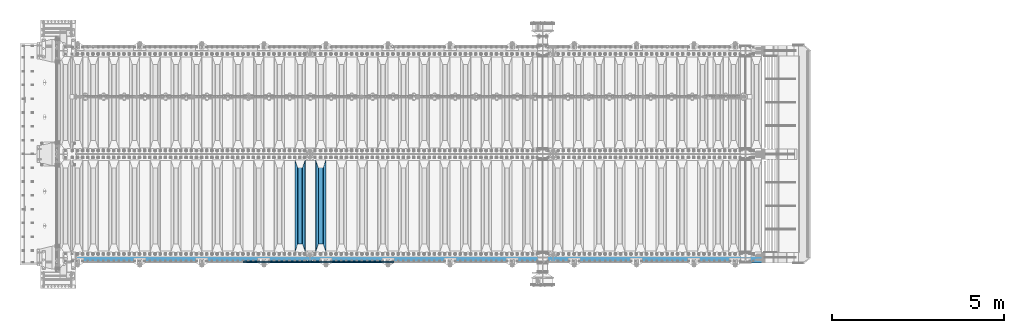
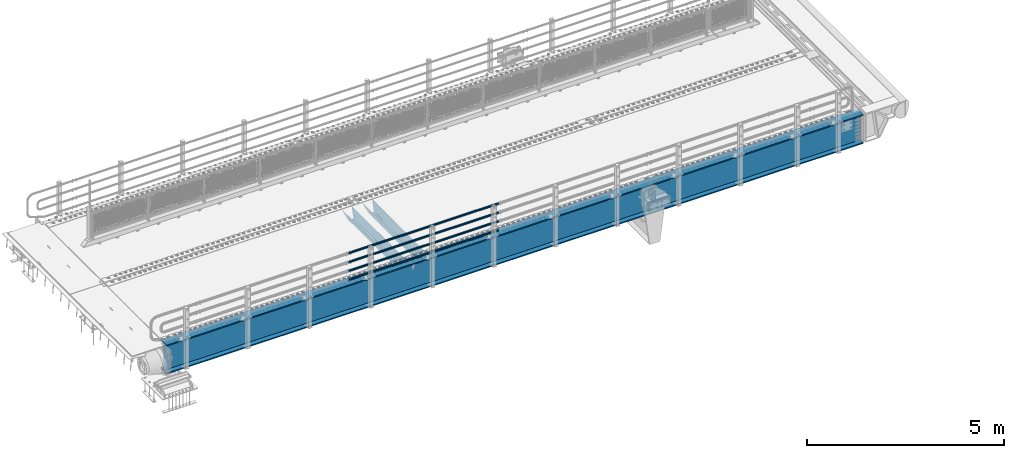
# One storey, part 118 of 242: 7 beams.
"""IFC2X3 building model written with IfcOpenShell, lengths in millimetres."""

from ifc_helpers import new_model, si_unit, frame, origin_with_axes, place, context, subcontext, project, spatial, faceted_brep, material, type_object, element, save


model = new_model("IFC2X3")

# Units and contexts
model_context = context("Model", 3, precision=1e-05, world=origin_with_axes())
body_context = subcontext(model_context, "Body", "Model", "MODEL_VIEW")
ifc_project = project(units=[si_unit("LENGTHUNIT", "METRE", prefix="MILLI"), si_unit("AREAUNIT", "SQUARE_METRE"), si_unit("VOLUMEUNIT", "CUBIC_METRE"), si_unit("MASSUNIT", "GRAM", prefix="KILO"), si_unit("TIMEUNIT", "SECOND"), si_unit("PLANEANGLEUNIT", "RADIAN"), si_unit("SOLIDANGLEUNIT", "STERADIAN"), si_unit("THERMODYNAMICTEMPERATUREUNIT", "DEGREE_CELSIUS"), si_unit("LUMINOUSINTENSITYUNIT", "LUMEN")], contexts=[model_context])

# Site, building, storey
site_placement = place(None, origin_with_axes())
site = spatial("IfcSite", under=ifc_project, at=site_placement, CompositionType="ELEMENT")
building_placement = place(site_placement, origin_with_axes())
building = spatial("IfcBuilding", under=site, at=building_placement, Name="Standard", CompositionType="ELEMENT")
storey_placement = place(building_placement, origin_with_axes())
storey = spatial("IfcBuildingStorey", under=building, at=storey_placement, Name="Undefined", CompositionType="ELEMENT", Elevation=0.0)

# Beams
ifc_material_1 = material()
beam_type_1 = type_object("IfcBeamType", PredefinedType="NOTDEFINED")
beam_1_placement = place(storey_placement, frame((-32722.0000000001, -24129.8499999999, 149.849999999726), z_axis=(0.0, 0.0, -1.0), x_axis=(-1.0, 0.0, 0.0)))
element("IfcBeam", 1, at=beam_1_placement, inside=storey, type_object=beam_type_1, material=ifc_material_1, context=body_context, shape_type="Brep", body=[
    faceted_brep([(0.0, -26.5499999999993, 0.0), (0.0, -24.5290015881765, 10.1602451292931), (4384.00249699992, -24.5290015881765, 10.1602451292931), (4384.00249699992, -26.5499999999993, 0.0), (0.0, -18.7736850405017, 18.7736850405028), (4384.00249699992, -18.7736850405017, 18.7736850405028), (0.0, -10.1602451292929, 24.5290015881747), (4384.00249699992, -10.1602451292929, 24.5290015881747), (0.0, 0.0, 26.55), (4384.00249699992, 0.0, 26.55), (0.0, 10.1602451292929, 24.5290015881747), (4384.00249699992, 10.1602451292929, 24.5290015881747), (0.0, 18.7736850405017, 18.7736850405028), (4384.00249699992, 18.7736850405017, 18.7736850405028), (0.0, 24.5290015881765, 10.1602451292931), (4384.00249699992, 24.5290015881765, 10.1602451292931), (0.0, 26.5499999999993, 0.0), (4384.00249699992, 26.5499999999993, 0.0), (0.0, 24.5290015881765, -10.1602451292931), (4384.00249699992, 24.5290015881765, -10.1602451292931), (0.0, 18.7736850405017, -18.7736850405028), (4384.00249699992, 18.7736850405017, -18.7736850405028), (0.0, 10.1602451292929, -24.5290015881747), (4384.00249699992, 10.1602451292929, -24.5290015881747), (0.0, 0.0, -26.55), (4384.00249699992, 0.0, -26.55), (0.0, -10.1602451292929, -24.5290015881747), (4384.00249699992, -10.1602451292929, -24.5290015881747), (0.0, -18.7736850405017, -18.7736850405028), (4384.00249699992, -18.7736850405017, -18.7736850405028), (0.0, -24.5290015881765, -10.1602451292931), (4384.00249699992, -24.5290015881765, -10.1602451292931), (0.0, -30.1500000000015, 0.0), (0.0, -27.8549679052157, -11.5379054858058), (4384.00249699992, -27.8549679052157, -11.5379054858075), (4384.00249699992, -30.1500000000015, 0.0), (0.0, -21.3192694527752, -21.3192694527752), (4384.00249699992, -21.3192694527752, -21.3192694527744), (0.0, -11.5379054858058, -27.8549679052157), (4384.00249699992, -11.5379054858058, -27.8549679052153), (0.0, 0.0, -30.1500000000015), (4384.00249699992, 0.0, -30.15), (0.0, 11.5379054858058, -27.8549679052157), (4384.00249699992, 11.5379054858058, -27.8549679052153), (0.0, 21.3192694527752, -21.3192694527752), (4384.00249699992, 21.3192694527752, -21.3192694527744), (0.0, 27.8549679052157, -11.5379054858058), (4384.00249699992, 27.8549679052157, -11.5379054858074), (0.0, 30.1500000000015, 0.0), (4384.00249699992, 30.1500000000015, 0.0), (0.0, 27.8549679052157, 11.5379054858058), (4384.00249699992, 27.8549679052157, 11.5379054858075), (0.0, 21.3192694527752, 21.3192694527752), (4384.00249699992, 21.3192694527752, 21.3192694527744), (0.0, 11.5379054858058, 27.8549679052157), (4384.00249699992, 11.5379054858058, 27.8549679052153), (0.0, 0.0, 30.1500000000015), (4384.00249699992, 0.0, 30.15), (0.0, -11.5379054858058, 27.8549679052157), (4384.00249699992, -11.5379054858058, 27.8549679052153), (0.0, -21.3192694527752, 21.3192694527752), (4384.00249699992, -21.3192694527752, 21.3192694527744), (0.0, -27.8549679052157, 11.5379054858058), (4384.00249699992, -27.8549679052157, 11.5379054858075)], [[[0, 1, 2, 3]], [[1, 4, 5, 2]], [[4, 6, 7, 5]], [[6, 8, 9, 7]], [[8, 10, 11, 9]], [[10, 12, 13, 11]], [[12, 14, 15, 13]], [[14, 16, 17, 15]], [[16, 18, 19, 17]], [[18, 20, 21, 19]], [[20, 22, 23, 21]], [[22, 24, 25, 23]], [[24, 26, 27, 25]], [[26, 28, 29, 27]], [[28, 30, 31, 29]], [[30, 0, 3, 31]], [[32, 33, 34, 35]], [[33, 36, 37, 34]], [[36, 38, 39, 37]], [[38, 40, 41, 39]], [[40, 42, 43, 41]], [[42, 44, 45, 43]], [[44, 46, 47, 45]], [[46, 48, 49, 47]], [[48, 50, 51, 49]], [[50, 52, 53, 51]], [[52, 54, 55, 53]], [[54, 56, 57, 55]], [[56, 58, 59, 57]], [[58, 60, 61, 59]], [[60, 62, 63, 61]], [[62, 32, 35, 63]], [[37, 39, 41, 43, 45, 47, 49, 51, 53, 55, 57, 59, 61, 63, 35, 34], [5, 7, 9, 11, 13, 15, 17, 19, 21, 23, 25, 27, 29, 31, 3, 2]], [[62, 60, 58, 56, 54, 52, 50, 48, 46, 44, 42, 40, 38, 36, 33, 32], [30, 28, 26, 24, 22, 20, 18, 16, 14, 12, 10, 8, 6, 4, 1, 0]]]),
])
beam_2_placement = place(storey_placement, frame((-32722.0000000001, -24129.8499999999, 420.149999999729), z_axis=(0.0, 0.0, -1.0), x_axis=(-1.0, 0.0, 0.0)))
element("IfcBeam", 2, at=beam_2_placement, inside=storey, type_object=beam_type_1, material=ifc_material_1, context=body_context, shape_type="Brep", body=[
    faceted_brep([(0.0, -26.5499999999993, 0.0), (0.0, -24.5290015881765, 10.1602451292931), (4384.00249699992, -24.5290015881765, 10.1602451292931), (4384.00249699992, -26.5499999999993, 0.0), (0.0, -18.7736850405017, 18.7736850405028), (4384.00249699992, -18.7736850405017, 18.7736850405028), (0.0, -10.1602451292929, 24.5290015881747), (4384.00249699992, -10.1602451292929, 24.5290015881747), (0.0, 0.0, 26.55), (4384.00249699992, 0.0, 26.55), (0.0, 10.1602451292929, 24.5290015881747), (4384.00249699992, 10.1602451292929, 24.5290015881747), (0.0, 18.7736850405017, 18.7736850405028), (4384.00249699992, 18.7736850405017, 18.7736850405028), (0.0, 24.5290015881765, 10.1602451292931), (4384.00249699992, 24.5290015881765, 10.1602451292931), (0.0, 26.5499999999993, 0.0), (4384.00249699992, 26.5499999999993, 0.0), (0.0, 24.5290015881765, -10.1602451292931), (4384.00249699992, 24.5290015881765, -10.1602451292931), (0.0, 18.7736850405017, -18.7736850405028), (4384.00249699992, 18.7736850405017, -18.7736850405028), (0.0, 10.1602451292929, -24.5290015881747), (4384.00249699992, 10.1602451292929, -24.5290015881747), (0.0, 0.0, -26.55), (4384.00249699992, 0.0, -26.55), (0.0, -10.1602451292929, -24.5290015881747), (4384.00249699992, -10.1602451292929, -24.5290015881747), (0.0, -18.7736850405017, -18.7736850405028), (4384.00249699992, -18.7736850405017, -18.7736850405028), (0.0, -24.5290015881765, -10.1602451292931), (4384.00249699992, -24.5290015881765, -10.1602451292931), (0.0, -30.1500000000015, 0.0), (0.0, -27.8549679052157, -11.5379054858058), (4384.00249699992, -27.8549679052157, -11.5379054858075), (4384.00249699992, -30.1500000000015, 0.0), (0.0, -21.3192694527752, -21.3192694527752), (4384.00249699992, -21.3192694527752, -21.3192694527744), (0.0, -11.5379054858058, -27.8549679052157), (4384.00249699992, -11.5379054858058, -27.8549679052153), (0.0, 0.0, -30.1500000000015), (4384.00249699992, 0.0, -30.15), (0.0, 11.5379054858058, -27.8549679052157), (4384.00249699992, 11.5379054858058, -27.8549679052153), (0.0, 21.3192694527752, -21.3192694527752), (4384.00249699992, 21.3192694527752, -21.3192694527744), (0.0, 27.8549679052157, -11.5379054858058), (4384.00249699992, 27.8549679052157, -11.5379054858074), (0.0, 30.1500000000015, 0.0), (4384.00249699992, 30.1500000000015, 0.0), (0.0, 27.8549679052157, 11.5379054858058), (4384.00249699992, 27.8549679052157, 11.5379054858075), (0.0, 21.3192694527752, 21.3192694527752), (4384.00249699992, 21.3192694527752, 21.3192694527744), (0.0, 11.5379054858058, 27.8549679052157), (4384.00249699992, 11.5379054858058, 27.8549679052153), (0.0, 0.0, 30.1500000000015), (4384.00249699992, 0.0, 30.15), (0.0, -11.5379054858058, 27.8549679052157), (4384.00249699992, -11.5379054858058, 27.8549679052153), (0.0, -21.3192694527752, 21.3192694527752), (4384.00249699992, -21.3192694527752, 21.3192694527744), (0.0, -27.8549679052157, 11.5379054858058), (4384.00249699992, -27.8549679052157, 11.5379054858075)], [[[0, 1, 2, 3]], [[1, 4, 5, 2]], [[4, 6, 7, 5]], [[6, 8, 9, 7]], [[8, 10, 11, 9]], [[10, 12, 13, 11]], [[12, 14, 15, 13]], [[14, 16, 17, 15]], [[16, 18, 19, 17]], [[18, 20, 21, 19]], [[20, 22, 23, 21]], [[22, 24, 25, 23]], [[24, 26, 27, 25]], [[26, 28, 29, 27]], [[28, 30, 31, 29]], [[30, 0, 3, 31]], [[32, 33, 34, 35]], [[33, 36, 37, 34]], [[36, 38, 39, 37]], [[38, 40, 41, 39]], [[40, 42, 43, 41]], [[42, 44, 45, 43]], [[44, 46, 47, 45]], [[46, 48, 49, 47]], [[48, 50, 51, 49]], [[50, 52, 53, 51]], [[52, 54, 55, 53]], [[54, 56, 57, 55]], [[56, 58, 59, 57]], [[58, 60, 61, 59]], [[60, 62, 63, 61]], [[62, 32, 35, 63]], [[37, 39, 41, 43, 45, 47, 49, 51, 53, 55, 57, 59, 61, 63, 35, 34], [5, 7, 9, 11, 13, 15, 17, 19, 21, 23, 25, 27, 29, 31, 3, 2]], [[62, 60, 58, 56, 54, 52, 50, 48, 46, 44, 42, 40, 38, 36, 33, 32], [30, 28, 26, 24, 22, 20, 18, 16, 14, 12, 10, 8, 6, 4, 1, 0]]]),
])
beam_3_placement = place(storey_placement, frame((-32722.0000000001, -24129.8499999999, 969.849999999726), z_axis=(0.0, 0.0, -1.0), x_axis=(-1.0, 0.0, 0.0)))
element("IfcBeam", 3, at=beam_3_placement, inside=storey, type_object=beam_type_1, material=ifc_material_1, context=body_context, shape_type="Brep", body=[
    faceted_brep([(0.0, -26.5499999999993, 0.0), (0.0, -24.5290015881765, 10.1602451292931), (4384.00249699992, -24.5290015881765, 10.1602451292931), (4384.00249699992, -26.5499999999993, 0.0), (0.0, -18.7736850405017, 18.7736850405028), (4384.00249699992, -18.7736850405017, 18.7736850405028), (0.0, -10.1602451292929, 24.5290015881747), (4384.00249699992, -10.1602451292929, 24.5290015881747), (0.0, 0.0, 26.55), (4384.00249699992, 0.0, 26.55), (0.0, 10.1602451292929, 24.5290015881747), (4384.00249699992, 10.1602451292929, 24.5290015881747), (0.0, 18.7736850405017, 18.7736850405028), (4384.00249699992, 18.7736850405017, 18.7736850405028), (0.0, 24.5290015881765, 10.1602451292931), (4384.00249699992, 24.5290015881765, 10.1602451292931), (0.0, 26.5499999999993, 0.0), (4384.00249699992, 26.5499999999993, 0.0), (0.0, 24.5290015881765, -10.1602451292931), (4384.00249699992, 24.5290015881765, -10.1602451292931), (0.0, 18.7736850405017, -18.7736850405028), (4384.00249699992, 18.7736850405017, -18.7736850405028), (0.0, 10.1602451292929, -24.5290015881747), (4384.00249699992, 10.1602451292929, -24.5290015881747), (0.0, 0.0, -26.55), (4384.00249699992, 0.0, -26.55), (0.0, -10.1602451292929, -24.5290015881747), (4384.00249699992, -10.1602451292929, -24.5290015881747), (0.0, -18.7736850405017, -18.7736850405028), (4384.00249699992, -18.7736850405017, -18.7736850405028), (0.0, -24.5290015881765, -10.1602451292931), (4384.00249699992, -24.5290015881765, -10.1602451292931), (0.0, -30.1500000000015, 0.0), (0.0, -27.8549679052157, -11.5379054858058), (4384.00249699992, -27.8549679052157, -11.5379054858075), (4384.00249699992, -30.1500000000015, 0.0), (0.0, -21.3192694527752, -21.3192694527752), (4384.00249699992, -21.3192694527752, -21.3192694527744), (0.0, -11.5379054858058, -27.8549679052157), (4384.00249699992, -11.5379054858058, -27.8549679052153), (0.0, 0.0, -30.1500000000015), (4384.00249699992, 0.0, -30.15), (0.0, 11.5379054858058, -27.8549679052157), (4384.00249699992, 11.5379054858058, -27.8549679052153), (0.0, 21.3192694527752, -21.3192694527752), (4384.00249699992, 21.3192694527752, -21.3192694527744), (0.0, 27.8549679052157, -11.5379054858058), (4384.00249699992, 27.8549679052157, -11.5379054858074), (0.0, 30.1500000000015, 0.0), (4384.00249699992, 30.1500000000015, 0.0), (0.0, 27.8549679052157, 11.5379054858058), (4384.00249699992, 27.8549679052157, 11.5379054858075), (0.0, 21.3192694527752, 21.3192694527752), (4384.00249699992, 21.3192694527752, 21.3192694527744), (0.0, 11.5379054858058, 27.8549679052157), (4384.00249699992, 11.5379054858058, 27.8549679052153), (0.0, 0.0, 30.1500000000015), (4384.00249699992, 0.0, 30.15), (0.0, -11.5379054858058, 27.8549679052157), (4384.00249699992, -11.5379054858058, 27.8549679052153), (0.0, -21.3192694527752, 21.3192694527752), (4384.00249699992, -21.3192694527752, 21.3192694527744), (0.0, -27.8549679052157, 11.5379054858058), (4384.00249699992, -27.8549679052157, 11.5379054858075)], [[[0, 1, 2, 3]], [[1, 4, 5, 2]], [[4, 6, 7, 5]], [[6, 8, 9, 7]], [[8, 10, 11, 9]], [[10, 12, 13, 11]], [[12, 14, 15, 13]], [[14, 16, 17, 15]], [[16, 18, 19, 17]], [[18, 20, 21, 19]], [[20, 22, 23, 21]], [[22, 24, 25, 23]], [[24, 26, 27, 25]], [[26, 28, 29, 27]], [[28, 30, 31, 29]], [[30, 0, 3, 31]], [[32, 33, 34, 35]], [[33, 36, 37, 34]], [[36, 38, 39, 37]], [[38, 40, 41, 39]], [[40, 42, 43, 41]], [[42, 44, 45, 43]], [[44, 46, 47, 45]], [[46, 48, 49, 47]], [[48, 50, 51, 49]], [[50, 52, 53, 51]], [[52, 54, 55, 53]], [[54, 56, 57, 55]], [[56, 58, 59, 57]], [[58, 60, 61, 59]], [[60, 62, 63, 61]], [[62, 32, 35, 63]], [[37, 39, 41, 43, 45, 47, 49, 51, 53, 55, 57, 59, 61, 63, 35, 34], [5, 7, 9, 11, 13, 15, 17, 19, 21, 23, 25, 27, 29, 31, 3, 2]], [[62, 60, 58, 56, 54, 52, 50, 48, 46, 44, 42, 40, 38, 36, 33, 32], [30, 28, 26, 24, 22, 20, 18, 16, 14, 12, 10, 8, 6, 4, 1, 0]]]),
])
beam_4_placement = place(storey_placement, frame((-32722.0000000001, -24129.8499999999, 689.849999999726), z_axis=(0.0, 0.0, -1.0), x_axis=(-1.0, 0.0, 0.0)))
element("IfcBeam", 4, at=beam_4_placement, inside=storey, type_object=beam_type_1, material=ifc_material_1, context=body_context, shape_type="Brep", body=[
    faceted_brep([(0.0, -26.5499999999993, 0.0), (0.0, -24.5290015881765, 10.1602451292931), (4384.00249699992, -24.5290015881765, 10.1602451292931), (4384.00249699992, -26.5499999999993, 0.0), (0.0, -18.7736850405017, 18.7736850405028), (4384.00249699992, -18.7736850405017, 18.7736850405028), (0.0, -10.1602451292929, 24.5290015881747), (4384.00249699992, -10.1602451292929, 24.5290015881747), (0.0, 0.0, 26.55), (4384.00249699992, 0.0, 26.55), (0.0, 10.1602451292929, 24.5290015881747), (4384.00249699992, 10.1602451292929, 24.5290015881747), (0.0, 18.7736850405017, 18.7736850405028), (4384.00249699992, 18.7736850405017, 18.7736850405028), (0.0, 24.5290015881765, 10.1602451292931), (4384.00249699992, 24.5290015881765, 10.1602451292931), (0.0, 26.5499999999993, 0.0), (4384.00249699992, 26.5499999999993, 0.0), (0.0, 24.5290015881765, -10.1602451292931), (4384.00249699992, 24.5290015881765, -10.1602451292931), (0.0, 18.7736850405017, -18.7736850405028), (4384.00249699992, 18.7736850405017, -18.7736850405028), (0.0, 10.1602451292929, -24.5290015881747), (4384.00249699992, 10.1602451292929, -24.5290015881747), (0.0, 0.0, -26.55), (4384.00249699992, 0.0, -26.55), (0.0, -10.1602451292929, -24.5290015881747), (4384.00249699992, -10.1602451292929, -24.5290015881747), (0.0, -18.7736850405017, -18.7736850405028), (4384.00249699992, -18.7736850405017, -18.7736850405028), (0.0, -24.5290015881765, -10.1602451292931), (4384.00249699992, -24.5290015881765, -10.1602451292931), (0.0, -30.1500000000015, 0.0), (0.0, -27.8549679052157, -11.5379054858058), (4384.00249699992, -27.8549679052157, -11.5379054858075), (4384.00249699992, -30.1500000000015, 0.0), (0.0, -21.3192694527752, -21.3192694527752), (4384.00249699992, -21.3192694527752, -21.3192694527744), (0.0, -11.5379054858058, -27.8549679052157), (4384.00249699992, -11.5379054858058, -27.8549679052153), (0.0, 0.0, -30.1500000000015), (4384.00249699992, 0.0, -30.15), (0.0, 11.5379054858058, -27.8549679052157), (4384.00249699992, 11.5379054858058, -27.8549679052153), (0.0, 21.3192694527752, -21.3192694527752), (4384.00249699992, 21.3192694527752, -21.3192694527744), (0.0, 27.8549679052157, -11.5379054858058), (4384.00249699992, 27.8549679052157, -11.5379054858074), (0.0, 30.1500000000015, 0.0), (4384.00249699992, 30.1500000000015, 0.0), (0.0, 27.8549679052157, 11.5379054858058), (4384.00249699992, 27.8549679052157, 11.5379054858075), (0.0, 21.3192694527752, 21.3192694527752), (4384.00249699992, 21.3192694527752, 21.3192694527744), (0.0, 11.5379054858058, 27.8549679052157), (4384.00249699992, 11.5379054858058, 27.8549679052153), (0.0, 0.0, 30.1500000000015), (4384.00249699992, 0.0, 30.15), (0.0, -11.5379054858058, 27.8549679052157), (4384.00249699992, -11.5379054858058, 27.8549679052153), (0.0, -21.3192694527752, 21.3192694527752), (4384.00249699992, -21.3192694527752, 21.3192694527744), (0.0, -27.8549679052157, 11.5379054858058), (4384.00249699992, -27.8549679052157, 11.5379054858075)], [[[0, 1, 2, 3]], [[1, 4, 5, 2]], [[4, 6, 7, 5]], [[6, 8, 9, 7]], [[8, 10, 11, 9]], [[10, 12, 13, 11]], [[12, 14, 15, 13]], [[14, 16, 17, 15]], [[16, 18, 19, 17]], [[18, 20, 21, 19]], [[20, 22, 23, 21]], [[22, 24, 25, 23]], [[24, 26, 27, 25]], [[26, 28, 29, 27]], [[28, 30, 31, 29]], [[30, 0, 3, 31]], [[32, 33, 34, 35]], [[33, 36, 37, 34]], [[36, 38, 39, 37]], [[38, 40, 41, 39]], [[40, 42, 43, 41]], [[42, 44, 45, 43]], [[44, 46, 47, 45]], [[46, 48, 49, 47]], [[48, 50, 51, 49]], [[50, 52, 53, 51]], [[52, 54, 55, 53]], [[54, 56, 57, 55]], [[56, 58, 59, 57]], [[58, 60, 61, 59]], [[60, 62, 63, 61]], [[62, 32, 35, 63]], [[37, 39, 41, 43, 45, 47, 49, 51, 53, 55, 57, 59, 61, 63, 35, 34], [5, 7, 9, 11, 13, 15, 17, 19, 21, 23, 25, 27, 29, 31, 3, 2]], [[62, 60, 58, 56, 54, 52, 50, 48, 46, 44, 42, 40, 38, 36, 33, 32], [30, 28, 26, 24, 22, 20, 18, 16, 14, 12, 10, 8, 6, 4, 1, 0]]]),
])
ifc_material_2 = material(Name="STEEL/S355N")
beam_type_2 = type_object("IfcBeamType", PredefinedType="NOTDEFINED")
beam_5_placement = place(storey_placement, frame((-34850.0, -23825.0, -115.0), z_axis=(0.0, 0.0, 1.0), x_axis=(0.0, 1.0, 0.0)))
element("IfcBeam", 5, at=beam_5_placement, inside=storey, type_object=beam_type_2, material=ifc_material_2, context=body_context, shape_type="Brep", body=[
    faceted_brep([(0.0, 150.0, 115.0), (0.0, 143.689999999999, 115.0), (2650.00000000297, 143.689999999999, 115.0), (2650.00000000297, 150.0, 115.0), (2650.00000000297, 142.059565218402, 110.000000003099), (2650.00000000297, 148.369565218403, 110.000000003099), (2441.90079219209, -80.1103600731112, -98.0992078077845), (2437.7588105432, -77.5672621345584, -102.241189456673), (2434.06523489747, -74.4080125315522, -105.934765102404), (2430.91086095089, -70.710272125576, -109.089139048974), (2428.37322971128, -66.5649389910068, -111.626770288588), (2426.51472138055, -62.0739139532889, -113.485278619323), (2425.38102192092, -57.3475956567672, -114.618978078955), (2424.99999999987, -52.5021667386536, -115.0), (2424.99999999987, 52.5021667386536, -115.0), (2425.38102192092, 57.3475956567672, -114.618978078955), (2426.51472138055, 62.0739139532889, -113.485278619323), (2428.37322971128, 66.5649389910068, -111.626770288588), (2430.91086095089, 70.710272125576, -109.089139048974), (2434.06523489747, 74.4080125315522, -105.934765102404), (2437.7588105432, 77.5672621345584, -102.241189456673), (2441.90079219209, 80.1103600731112, -98.0992078077846), (2446.38936140511, 81.9747917625791, -93.6106385947584), (2448.2494850041, 76.2713538057251, -91.7505149957729), (2444.62967112262, 74.76777986261, -95.3703288772456), (2441.28936334126, 72.7168944282894, -98.710636658607), (2438.31067330438, 70.1691124903846, -101.689326695487), (2435.76682334747, 67.1870637758839, -104.233176652398), (2433.72034654133, 63.8440531834895, -106.279653458539), (2432.22154950042, 60.222258798236, -107.778450499454), (2431.30727574265, 56.4107117849089, -108.692724257221), (2430.99999999987, 52.5031078186876, -109.0), (2430.99999999987, -52.5031078186876, -109.0), (2431.30727574265, -56.4107117849089, -108.692724257221), (2432.22154950042, -60.222258798236, -107.778450499454), (2433.72034654133, -63.8440531834895, -106.279653458539), (2435.76682334747, -67.1870637758839, -104.233176652398), (2438.31067330438, -70.1691124903846, -101.689326695487), (2441.28936334126, -72.7168944282894, -98.7106366586071), (2444.62967112262, -74.76777986261, -95.3703288772457), (2448.2494850041, -76.2713538057251, -91.7505149957729), (2650.00000000297, -142.059565218402, 110.000000003099), (2650.00000000297, -148.369565218403, 110.000000003099), (2446.38936140511, -81.9747917625791, -93.6106385947584), (2650.00000000297, -143.689999999999, 115.0), (2650.00000000297, -150.0, 115.0), (0.0, -143.689999999999, 115.0), (0.0, -150.0, 115.0), (0.0, -148.369565218261, 110.000000002669), (203.610638597427, -81.9747917625791, -93.6106385947584), (208.099207810454, -80.1103600731112, -98.0992078077845), (212.241189459342, -77.5672621345584, -102.241189456673), (215.934765105074, -74.4080125315522, -105.934765102404), (219.089139051644, -70.710272125576, -109.089139048974), (221.626770291256, -66.5649389910068, -111.626770288588), (223.485278621993, -62.0739139532889, -113.485278619323), (224.618978081624, -57.3475956567672, -114.618978078955), (225.00000000267, -52.5021667386536, -115.0), (225.00000000267, 52.5021667386536, -115.0), (224.618978081624, 57.3475956567672, -114.618978078955), (223.485278621993, 62.0739139532889, -113.485278619323), (221.626770291256, 66.5649389910068, -111.626770288588), (219.089139051644, 70.710272125576, -109.089139048974), (215.934765105074, 74.4080125315522, -105.934765102404), (212.241189459342, 77.5672621345584, -102.241189456673), (208.099207810454, 80.1103600731112, -98.0992078077846), (203.610638597427, 81.9747917625791, -93.6106385947584), (0.0, 148.369565218261, 110.000000002669), (0.0, 142.05956521826, 110.000000002669), (201.750514998443, 76.2713538057251, -91.7505149957729), (205.370328879915, 74.76777986261, -95.3703288772456), (208.710636661275, 72.7168944282894, -98.710636658607), (211.689326698157, 70.1691124903846, -101.689326695487), (214.233176655067, 67.1870637758839, -104.233176652398), (216.279653461206, 63.8440531834895, -106.279653458539), (217.778450502123, 60.222258798236, -107.778450499454), (218.69272425989, 56.4107117849089, -108.692724257221), (219.00000000267, 52.5031078186876, -109.0), (219.00000000267, -52.5031078186876, -109.0), (218.69272425989, -56.4107117849089, -108.692724257221), (217.778450502123, -60.222258798236, -107.778450499454), (216.279653461206, -63.8440531834895, -106.279653458539), (214.233176655067, -67.1870637758839, -104.233176652398), (211.689326698157, -70.1691124903846, -101.689326695487), (208.710636661275, -72.7168944282894, -98.7106366586071), (205.370328879915, -74.76777986261, -95.3703288772457), (201.750514998443, -76.2713538057251, -91.7505149957729), (0.0, -142.05956521826, 110.000000002669)], [[[0, 1, 2, 3]], [[3, 2, 4, 5]], [[6, 7, 8, 9, 10, 11, 12, 13, 14, 15, 16, 17, 18, 19, 20, 21, 22, 5, 4, 23, 24, 25, 26, 27, 28, 29, 30, 31, 32, 33, 34, 35, 36, 37, 38, 39, 40, 41, 42, 43]], [[44, 45, 42, 41]], [[46, 47, 45, 44]], [[43, 42, 45, 47, 48, 49]], [[6, 43, 49, 50]], [[7, 6, 50, 51]], [[8, 7, 51, 52]], [[9, 8, 52, 53]], [[10, 9, 53, 54]], [[11, 10, 54, 55]], [[12, 11, 55, 56]], [[13, 12, 56, 57]], [[14, 13, 57, 58]], [[15, 14, 58, 59]], [[16, 15, 59, 60]], [[17, 16, 60, 61]], [[18, 17, 61, 62]], [[19, 18, 62, 63]], [[20, 19, 63, 64]], [[21, 20, 64, 65]], [[22, 21, 65, 66]], [[0, 3, 5, 22, 66, 67]], [[1, 0, 67, 68]], [[23, 4, 2, 1, 68, 69]], [[24, 23, 69, 70]], [[25, 24, 70, 71]], [[26, 25, 71, 72]], [[27, 26, 72, 73]], [[28, 27, 73, 74]], [[29, 28, 74, 75]], [[30, 29, 75, 76]], [[31, 30, 76, 77]], [[32, 31, 77, 78]], [[33, 32, 78, 79]], [[34, 33, 79, 80]], [[35, 34, 80, 81]], [[36, 35, 81, 82]], [[37, 36, 82, 83]], [[38, 37, 83, 84]], [[39, 38, 84, 85]], [[40, 39, 85, 86]], [[46, 44, 41, 40, 86, 87]], [[47, 46, 87, 48]], [[86, 85, 84, 83, 82, 81, 80, 79, 78, 77, 76, 75, 74, 73, 72, 71, 70, 69, 68, 67, 66, 65, 64, 63, 62, 61, 60, 59, 58, 57, 56, 55, 54, 53, 52, 51, 50, 49, 48, 87]]]),
])
beam_6_placement = place(storey_placement, frame((-35450.0, -23825.0, -115.0), z_axis=(0.0, 0.0, 1.0), x_axis=(0.0, 1.0, 0.0)))
element("IfcBeam", 6, at=beam_6_placement, inside=storey, type_object=beam_type_2, material=ifc_material_2, context=body_context, shape_type="Brep", body=[
    faceted_brep([(0.0, 150.0, 115.0), (0.0, 143.689999999999, 115.0), (2650.00000000297, 143.689999999999, 115.0), (2650.00000000297, 150.0, 115.0), (2650.00000000297, 142.059565218402, 110.000000003099), (2650.00000000297, 148.369565218403, 110.000000003099), (2441.90079219209, -80.1103600731112, -98.0992078077845), (2437.7588105432, -77.5672621345584, -102.241189456673), (2434.06523489747, -74.4080125315522, -105.934765102404), (2430.91086095089, -70.710272125576, -109.089139048974), (2428.37322971128, -66.5649389910068, -111.626770288588), (2426.51472138055, -62.0739139532889, -113.485278619323), (2425.38102192092, -57.3475956567672, -114.618978078955), (2424.99999999987, -52.5021667386536, -115.0), (2424.99999999987, 52.5021667386536, -115.0), (2425.38102192092, 57.3475956567672, -114.618978078955), (2426.51472138055, 62.0739139532889, -113.485278619323), (2428.37322971128, 66.5649389910068, -111.626770288588), (2430.91086095089, 70.710272125576, -109.089139048974), (2434.06523489747, 74.4080125315522, -105.934765102404), (2437.7588105432, 77.5672621345584, -102.241189456673), (2441.90079219209, 80.1103600731112, -98.0992078077846), (2446.38936140511, 81.9747917625791, -93.6106385947584), (2448.2494850041, 76.2713538057251, -91.7505149957729), (2444.62967112262, 74.76777986261, -95.3703288772456), (2441.28936334126, 72.7168944282894, -98.710636658607), (2438.31067330438, 70.1691124903846, -101.689326695487), (2435.76682334747, 67.1870637758839, -104.233176652398), (2433.72034654133, 63.8440531834895, -106.279653458539), (2432.22154950042, 60.222258798236, -107.778450499454), (2431.30727574265, 56.4107117849089, -108.692724257221), (2430.99999999987, 52.5031078186876, -109.0), (2430.99999999987, -52.5031078186876, -109.0), (2431.30727574265, -56.4107117849089, -108.692724257221), (2432.22154950042, -60.222258798236, -107.778450499454), (2433.72034654133, -63.8440531834895, -106.279653458539), (2435.76682334747, -67.1870637758839, -104.233176652398), (2438.31067330438, -70.1691124903846, -101.689326695487), (2441.28936334126, -72.7168944282894, -98.7106366586071), (2444.62967112262, -74.76777986261, -95.3703288772457), (2448.2494850041, -76.2713538057251, -91.7505149957729), (2650.00000000297, -142.059565218402, 110.000000003099), (2650.00000000297, -148.369565218403, 110.000000003099), (2446.38936140511, -81.9747917625791, -93.6106385947584), (2650.00000000297, -143.689999999999, 115.0), (2650.00000000297, -150.0, 115.0), (0.0, -143.689999999999, 115.0), (0.0, -150.0, 115.0), (0.0, -148.369565218261, 110.000000002669), (203.610638597427, -81.9747917625791, -93.6106385947584), (208.099207810454, -80.1103600731112, -98.0992078077845), (212.241189459342, -77.5672621345584, -102.241189456673), (215.934765105074, -74.4080125315522, -105.934765102404), (219.089139051644, -70.710272125576, -109.089139048974), (221.626770291256, -66.5649389910068, -111.626770288588), (223.485278621993, -62.0739139532889, -113.485278619323), (224.618978081624, -57.3475956567672, -114.618978078955), (225.00000000267, -52.5021667386536, -115.0), (225.00000000267, 52.5021667386536, -115.0), (224.618978081624, 57.3475956567672, -114.618978078955), (223.485278621993, 62.0739139532889, -113.485278619323), (221.626770291256, 66.5649389910068, -111.626770288588), (219.089139051644, 70.710272125576, -109.089139048974), (215.934765105074, 74.4080125315522, -105.934765102404), (212.241189459342, 77.5672621345584, -102.241189456673), (208.099207810454, 80.1103600731112, -98.0992078077846), (203.610638597427, 81.9747917625791, -93.6106385947584), (0.0, 148.369565218261, 110.000000002669), (0.0, 142.05956521826, 110.000000002669), (201.750514998443, 76.2713538057251, -91.7505149957729), (205.370328879915, 74.76777986261, -95.3703288772456), (208.710636661275, 72.7168944282894, -98.710636658607), (211.689326698157, 70.1691124903846, -101.689326695487), (214.233176655067, 67.1870637758839, -104.233176652398), (216.279653461206, 63.8440531834895, -106.279653458539), (217.778450502123, 60.222258798236, -107.778450499454), (218.69272425989, 56.4107117849089, -108.692724257221), (219.00000000267, 52.5031078186876, -109.0), (219.00000000267, -52.5031078186876, -109.0), (218.69272425989, -56.4107117849089, -108.692724257221), (217.778450502123, -60.222258798236, -107.778450499454), (216.279653461206, -63.8440531834895, -106.279653458539), (214.233176655067, -67.1870637758839, -104.233176652398), (211.689326698157, -70.1691124903846, -101.689326695487), (208.710636661275, -72.7168944282894, -98.7106366586071), (205.370328879915, -74.76777986261, -95.3703288772457), (201.750514998443, -76.2713538057251, -91.7505149957729), (0.0, -142.05956521826, 110.000000002669)], [[[0, 1, 2, 3]], [[3, 2, 4, 5]], [[6, 7, 8, 9, 10, 11, 12, 13, 14, 15, 16, 17, 18, 19, 20, 21, 22, 5, 4, 23, 24, 25, 26, 27, 28, 29, 30, 31, 32, 33, 34, 35, 36, 37, 38, 39, 40, 41, 42, 43]], [[44, 45, 42, 41]], [[46, 47, 45, 44]], [[43, 42, 45, 47, 48, 49]], [[6, 43, 49, 50]], [[7, 6, 50, 51]], [[8, 7, 51, 52]], [[9, 8, 52, 53]], [[10, 9, 53, 54]], [[11, 10, 54, 55]], [[12, 11, 55, 56]], [[13, 12, 56, 57]], [[14, 13, 57, 58]], [[15, 14, 58, 59]], [[16, 15, 59, 60]], [[17, 16, 60, 61]], [[18, 17, 61, 62]], [[19, 18, 62, 63]], [[20, 19, 63, 64]], [[21, 20, 64, 65]], [[22, 21, 65, 66]], [[0, 3, 5, 22, 66, 67]], [[1, 0, 67, 68]], [[23, 4, 2, 1, 68, 69]], [[24, 23, 69, 70]], [[25, 24, 70, 71]], [[26, 25, 71, 72]], [[27, 26, 72, 73]], [[28, 27, 73, 74]], [[29, 28, 74, 75]], [[30, 29, 75, 76]], [[31, 30, 76, 77]], [[32, 31, 77, 78]], [[33, 32, 78, 79]], [[34, 33, 79, 80]], [[35, 34, 80, 81]], [[36, 35, 81, 82]], [[37, 36, 82, 83]], [[38, 37, 83, 84]], [[39, 38, 84, 85]], [[40, 39, 85, 86]], [[46, 44, 41, 40, 86, 87]], [[47, 46, 87, 48]], [[86, 85, 84, 83, 82, 81, 80, 79, 78, 77, 76, 75, 74, 73, 72, 71, 70, 69, 68, 67, 66, 65, 64, 63, 62, 61, 60, 59, 58, 57, 56, 55, 54, 53, 52, 51, 50, 49, 48, 87]]]),
])
beam_type_3 = type_object("IfcBeamType", Name="HEB900", PredefinedType="NOTDEFINED")
beam_7_placement = place(storey_placement, frame((-42440.0, -24000.0, -450.0), z_axis=(0.0, 0.0, 1.0), x_axis=(1.0, 0.0, 0.0)))
element("IfcBeam", 7, at=beam_7_placement, inside=storey, type_object=beam_type_3, material=ifc_material_2, ObjectType="HEB900", context=body_context, shape_type="Brep", body=[
    faceted_brep([(0.0, 150.0, -450.0), (0.0, 150.0, -415.0), (20380.0, 150.0, -415.0), (20380.0, 150.0, -450.0), (0.0, 9.25, -415.0), (20380.0, 9.25, -415.0), (0.0, 9.25, 415.0), (20380.0, 9.25, 415.0), (0.0, 150.0, 415.0), (20380.0, 150.0, 415.0), (0.0, 150.0, 450.0), (20380.0, 150.0, 450.0), (0.0, -150.0, 450.0), (20380.0, -150.0, 450.0), (0.0, -150.0, 415.0), (20380.0, -150.0, 415.0), (0.0, -9.25, 415.0), (20380.0, -9.25, 415.0), (0.0, -9.25, -415.0), (20380.0, -9.25, -415.0), (0.0, -150.0, -415.0), (20380.0, -150.0, -415.0), (0.0, -150.0, -450.0), (20380.0, -150.0, -450.0)], [[[0, 1, 2, 3]], [[1, 4, 5, 2]], [[4, 6, 7, 5]], [[6, 8, 9, 7]], [[8, 10, 11, 9]], [[10, 12, 13, 11]], [[12, 14, 15, 13]], [[14, 16, 17, 15]], [[16, 18, 19, 17]], [[18, 20, 21, 19]], [[20, 22, 23, 21]], [[22, 0, 3, 23]], [[5, 7, 9, 11, 13, 15, 17, 19, 21, 23, 3, 2]], [[22, 20, 18, 16, 14, 12, 10, 8, 6, 4, 1, 0]]]),
])

save(model, "model.ifc")
